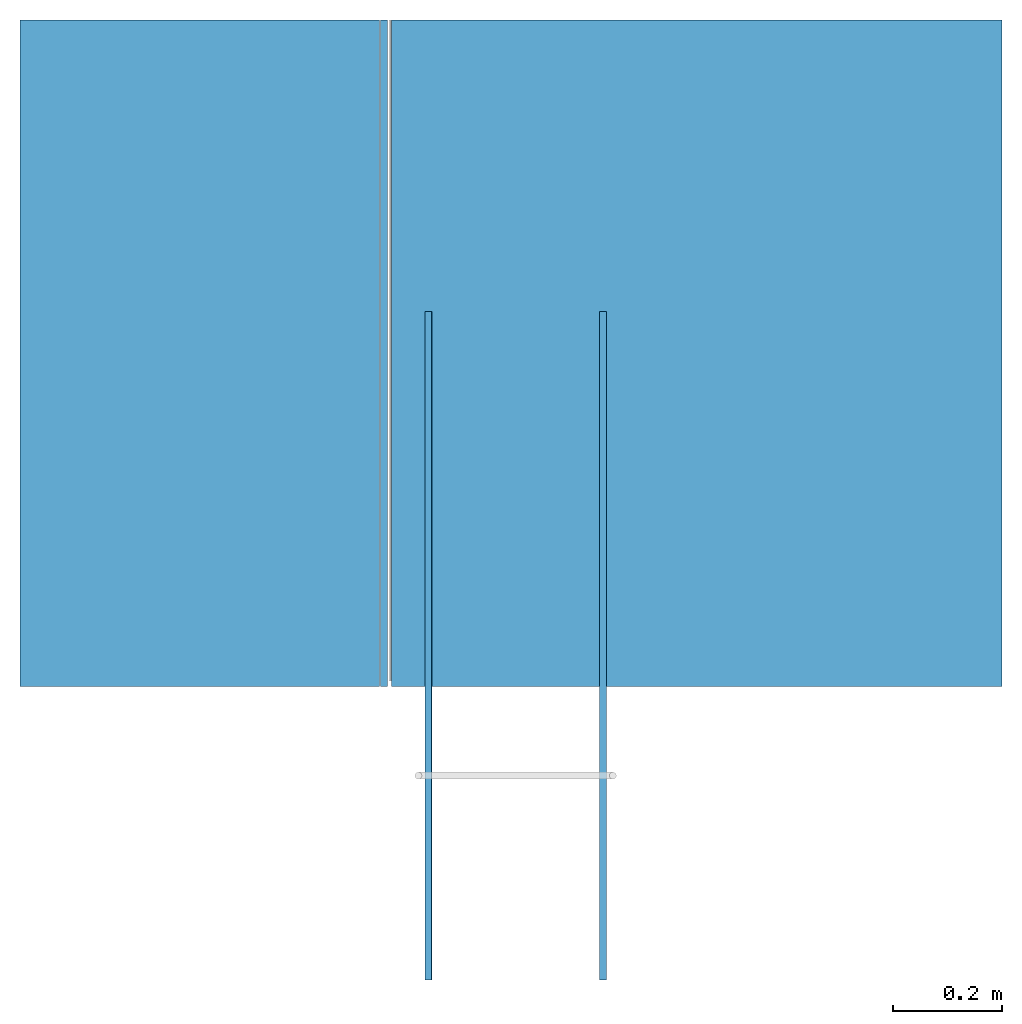
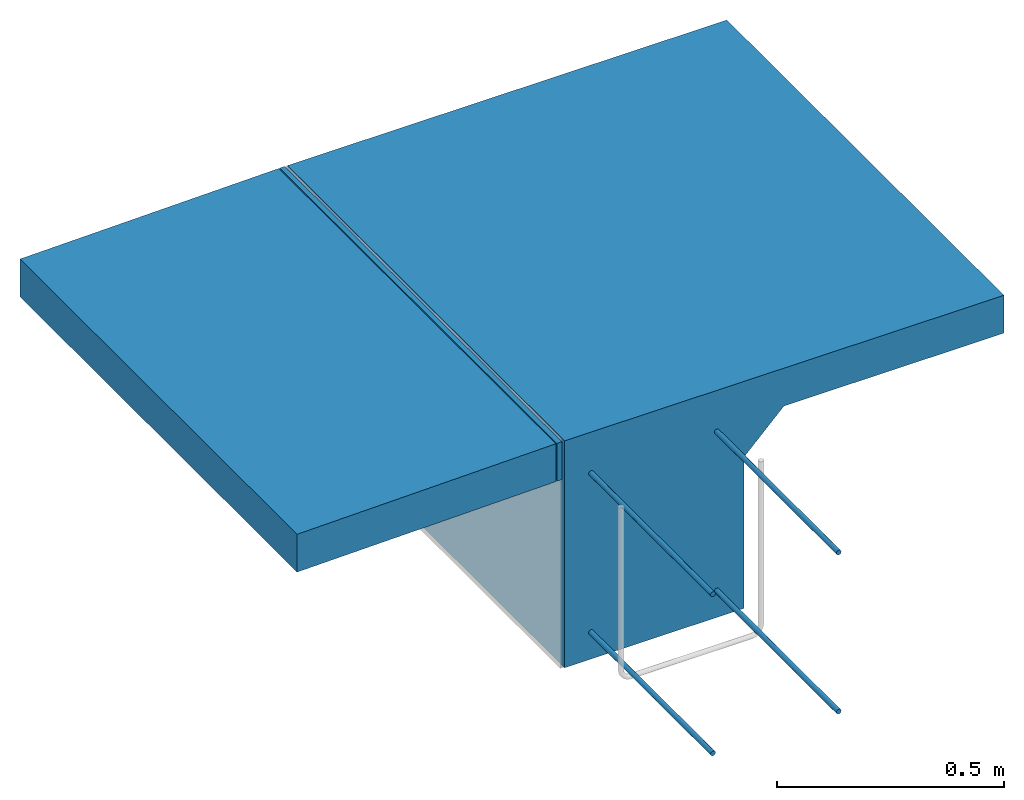
# One storey, part 1 of 2: 7 walls.
"""IFC4 building model written with IfcOpenShell, lengths in feet."""

from ifc_helpers import new_model, entity, si_unit, converted_unit, derived_unit, direction, frame, frame_2d, origin, place, context, subcontext, project, spatial, rectangle, extrude, material, type_object, element, save


model = new_model("IFC4")

# Units and contexts
model_context = context("Model", 3, precision=0.0001, world=origin(), true_north=direction((6.12303176911189e-17, 1.0)))
body_context = subcontext(model_context, "Body", "Model", "MODEL_VIEW")
ifc_project = project(units=[converted_unit("LENGTHUNIT", "FOOT", entity("IfcRatioMeasure", 0.3048), si_unit("LENGTHUNIT", "METRE"), dimensions=[1, 0, 0, 0, 0, 0, 0]), converted_unit("AREAUNIT", "SQUARE FOOT", entity("IfcRatioMeasure", 0.09290304), si_unit("AREAUNIT", "SQUARE_METRE"), dimensions=[2, 0, 0, 0, 0, 0, 0]), converted_unit("VOLUMEUNIT", "CUBIC FOOT", entity("IfcRatioMeasure", 0.028316846592), si_unit("VOLUMEUNIT", "CUBIC_METRE"), dimensions=[3, 0, 0, 0, 0, 0, 0]), converted_unit("PLANEANGLEUNIT", "DEGREE", entity("IfcRatioMeasure", 0.0174532925199433), si_unit("PLANEANGLEUNIT", "RADIAN"), dimensions=[0, 0, 0, 0, 0, 0, 0]), si_unit("MASSUNIT", "GRAM", prefix="KILO"), derived_unit("MASSDENSITYUNIT", [(si_unit("MASSUNIT", "GRAM", prefix="KILO"), 1), (si_unit("LENGTHUNIT", "METRE"), -3)]), derived_unit("MOMENTOFINERTIAUNIT", [(si_unit("LENGTHUNIT", "METRE"), 4)]), si_unit("TIMEUNIT", "SECOND"), si_unit("FREQUENCYUNIT", "HERTZ"), si_unit("THERMODYNAMICTEMPERATUREUNIT", "DEGREE_CELSIUS"), derived_unit("THERMALTRANSMITTANCEUNIT", [(si_unit("MASSUNIT", "GRAM", prefix="KILO"), 1), (si_unit("THERMODYNAMICTEMPERATUREUNIT", "KELVIN"), -1), (si_unit("TIMEUNIT", "SECOND"), -3)]), derived_unit("VOLUMETRICFLOWRATEUNIT", [(si_unit("LENGTHUNIT", "METRE"), 3), (si_unit("TIMEUNIT", "SECOND"), -1)]), si_unit("ELECTRICCURRENTUNIT", "AMPERE"), si_unit("ELECTRICVOLTAGEUNIT", "VOLT"), si_unit("POWERUNIT", "WATT"), si_unit("FORCEUNIT", "NEWTON"), si_unit("ILLUMINANCEUNIT", "LUX"), si_unit("LUMINOUSFLUXUNIT", "LUMEN"), si_unit("LUMINOUSINTENSITYUNIT", "CANDELA"), derived_unit("USERDEFINED", [(si_unit("MASSUNIT", "GRAM", prefix="KILO"), -1), (si_unit("LENGTHUNIT", "METRE"), -2), (si_unit("TIMEUNIT", "SECOND"), 3), (si_unit("LUMINOUSFLUXUNIT", "LUMEN"), 1)]), derived_unit("LINEARVELOCITYUNIT", [(si_unit("LENGTHUNIT", "METRE"), 1), (si_unit("TIMEUNIT", "SECOND"), -1)]), si_unit("PRESSUREUNIT", "PASCAL"), derived_unit("USERDEFINED", [(si_unit("LENGTHUNIT", "METRE"), -2), (si_unit("MASSUNIT", "GRAM", prefix="KILO"), 1), (si_unit("TIMEUNIT", "SECOND"), -2)]), derived_unit("LINEARFORCEUNIT", [(si_unit("MASSUNIT", "GRAM", prefix="KILO"), 1), (si_unit("LENGTHUNIT", "METRE"), 1), (si_unit("TIMEUNIT", "SECOND"), -2), (si_unit("LENGTHUNIT", "METRE"), -1)]), derived_unit("PLANARFORCEUNIT", [(si_unit("MASSUNIT", "GRAM", prefix="KILO"), 1), (si_unit("LENGTHUNIT", "METRE"), 1), (si_unit("TIMEUNIT", "SECOND"), -2), (si_unit("LENGTHUNIT", "METRE"), -2)])], contexts=[model_context])

# Site, building, storey
site_placement = place(None, origin())
site = spatial("IfcSite", under=ifc_project, at=site_placement, CompositionType="ELEMENT")
building_placement = place(site_placement, origin())
building = spatial("IfcBuilding", under=site, at=building_placement, CompositionType="ELEMENT")
storey_placement = place(building_placement, frame((0.0, 0.0, -8.0)))
storey = spatial("IfcBuildingStorey", under=building, at=storey_placement, CompositionType="ELEMENT", Elevation=-8.0)

# Walls
ifc_material_1 = material(Category="Materials")
wall_type_1 = type_object("IfcWallType", Name="Generic Models 680:Generic Models 1", PredefinedType="NOTDEFINED", material=ifc_material_1)
wall_1_placement = place(storey_placement, frame((1459.27121173765, 2.0, 6.0), z_axis=(0.0, 0.0, 1.0), x_axis=(0.0, 1.0, 0.0)))
cartesian_point_1 = entity("IfcCartesianPoint", [4.0, 0.0, 2.0])
vertex_point_1 = entity("IfcVertexPoint", cartesian_point_1)
cartesian_point_2 = entity("IfcCartesianPoint", [4.0, -3.66175012569693, 2.0])
vertex_point_2 = entity("IfcVertexPoint", cartesian_point_2)
ifc_direction_1 = entity("IfcDirection", [0.0, -1.0, 0.0])
edge_curve_1 = entity("IfcEdgeCurve", vertex_point_1, vertex_point_2, entity("IfcTrimmedCurve", entity("IfcLine", cartesian_point_1, entity("IfcVector", ifc_direction_1, 1.0)), [cartesian_point_1], [cartesian_point_2], True, "CARTESIAN"), True)
cartesian_point_3 = entity("IfcCartesianPoint", [4.0, -3.66175012569693, 1.66666666666667])
vertex_point_3 = entity("IfcVertexPoint", cartesian_point_3)
ifc_direction_2 = entity("IfcDirection", [0.0, 0.0, -1.0])
edge_curve_2 = entity("IfcEdgeCurve", vertex_point_2, vertex_point_3, entity("IfcTrimmedCurve", entity("IfcLine", cartesian_point_2, entity("IfcVector", ifc_direction_2, 1.0)), [cartesian_point_2], [cartesian_point_3], True, "CARTESIAN"), True)
cartesian_point_4 = entity("IfcCartesianPoint", [4.0, -1.82841679236344, 1.66666666666665])
vertex_point_4 = entity("IfcVertexPoint", cartesian_point_4)
ifc_direction_3 = entity("IfcDirection", [0.0, 1.0, 0.0])
edge_curve_3 = entity("IfcEdgeCurve", vertex_point_3, vertex_point_4, entity("IfcTrimmedCurve", entity("IfcLine", cartesian_point_3, entity("IfcVector", ifc_direction_3, 1.0)), [cartesian_point_3], [cartesian_point_4], True, "CARTESIAN"), True)
cartesian_point_5 = entity("IfcCartesianPoint", [4.0, -1.49508345903018, 1.33333333333333])
vertex_point_5 = entity("IfcVertexPoint", cartesian_point_5)
edge_curve_4 = entity("IfcEdgeCurve", vertex_point_4, vertex_point_5, entity("IfcTrimmedCurve", entity("IfcLine", cartesian_point_4, entity("IfcVector", entity("IfcDirection", [0.0, 0.707106781186483, -0.707106781186612]), 1.0)), [cartesian_point_4], [cartesian_point_5], True, "CARTESIAN"), True)
cartesian_point_6 = entity("IfcCartesianPoint", [4.0, -1.49508345903018, 0.0])
vertex_point_6 = entity("IfcVertexPoint", cartesian_point_6)
edge_curve_5 = entity("IfcEdgeCurve", vertex_point_5, vertex_point_6, entity("IfcTrimmedCurve", entity("IfcLine", cartesian_point_5, entity("IfcVector", ifc_direction_2, 1.0)), [cartesian_point_5], [cartesian_point_6], True, "CARTESIAN"), True)
cartesian_point_7 = entity("IfcCartesianPoint", [4.0, 0.0, 0.0])
vertex_point_7 = entity("IfcVertexPoint", cartesian_point_7)
edge_curve_6 = entity("IfcEdgeCurve", vertex_point_6, vertex_point_7, entity("IfcTrimmedCurve", entity("IfcLine", cartesian_point_6, entity("IfcVector", ifc_direction_3, 1.0)), [cartesian_point_6], [cartesian_point_7], True, "CARTESIAN"), True)
ifc_direction_4 = entity("IfcDirection", [0.0, 0.0, 1.0])
edge_curve_7 = entity("IfcEdgeCurve", vertex_point_7, vertex_point_1, entity("IfcTrimmedCurve", entity("IfcLine", cartesian_point_7, entity("IfcVector", ifc_direction_4, 1.0)), [cartesian_point_7], [cartesian_point_1], True, "CARTESIAN"), True)
ifc_direction_5 = entity("IfcDirection", [1.0, 0.0, 0.0])
cartesian_point_8 = entity("IfcCartesianPoint", [0.0, 0.0, 2.0])
vertex_point_8 = entity("IfcVertexPoint", cartesian_point_8)
cartesian_point_9 = entity("IfcCartesianPoint", [0.0, 0.0, 0.0])
vertex_point_9 = entity("IfcVertexPoint", cartesian_point_9)
edge_curve_8 = entity("IfcEdgeCurve", vertex_point_8, vertex_point_9, entity("IfcTrimmedCurve", entity("IfcLine", cartesian_point_8, entity("IfcVector", ifc_direction_2, 1.0)), [cartesian_point_8], [cartesian_point_9], True, "CARTESIAN"), True)
cartesian_point_10 = entity("IfcCartesianPoint", [0.0, -1.49508345903018, 0.0])
vertex_point_10 = entity("IfcVertexPoint", cartesian_point_10)
edge_curve_9 = entity("IfcEdgeCurve", vertex_point_9, vertex_point_10, entity("IfcTrimmedCurve", entity("IfcLine", cartesian_point_9, entity("IfcVector", ifc_direction_1, 1.0)), [cartesian_point_9], [cartesian_point_10], True, "CARTESIAN"), True)
cartesian_point_11 = entity("IfcCartesianPoint", [0.0, -1.49508345903018, 1.33333333333334])
vertex_point_11 = entity("IfcVertexPoint", cartesian_point_11)
edge_curve_10 = entity("IfcEdgeCurve", vertex_point_10, vertex_point_11, entity("IfcTrimmedCurve", entity("IfcLine", cartesian_point_10, entity("IfcVector", ifc_direction_4, 1.0)), [cartesian_point_10], [cartesian_point_11], True, "CARTESIAN"), True)
cartesian_point_12 = entity("IfcCartesianPoint", [0.0, -1.82841679236344, 1.66666666666665])
vertex_point_12 = entity("IfcVertexPoint", cartesian_point_12)
edge_curve_11 = entity("IfcEdgeCurve", vertex_point_11, vertex_point_12, entity("IfcTrimmedCurve", entity("IfcLine", cartesian_point_11, entity("IfcVector", entity("IfcDirection", [0.0, -0.707106781186483, 0.707106781186612]), 1.0)), [cartesian_point_11], [cartesian_point_12], True, "CARTESIAN"), True)
cartesian_point_13 = entity("IfcCartesianPoint", [0.0, -3.66175012569693, 1.66666666666667])
vertex_point_13 = entity("IfcVertexPoint", cartesian_point_13)
edge_curve_12 = entity("IfcEdgeCurve", vertex_point_12, vertex_point_13, entity("IfcTrimmedCurve", entity("IfcLine", cartesian_point_12, entity("IfcVector", ifc_direction_1, 1.0)), [cartesian_point_12], [cartesian_point_13], True, "CARTESIAN"), True)
cartesian_point_14 = entity("IfcCartesianPoint", [0.0, -3.66175012569693, 2.0])
vertex_point_14 = entity("IfcVertexPoint", cartesian_point_14)
edge_curve_13 = entity("IfcEdgeCurve", vertex_point_13, vertex_point_14, entity("IfcTrimmedCurve", entity("IfcLine", cartesian_point_13, entity("IfcVector", ifc_direction_4, 1.0)), [cartesian_point_13], [cartesian_point_14], True, "CARTESIAN"), True)
edge_curve_14 = entity("IfcEdgeCurve", vertex_point_14, vertex_point_8, entity("IfcTrimmedCurve", entity("IfcLine", cartesian_point_14, entity("IfcVector", ifc_direction_3, 1.0)), [cartesian_point_14], [cartesian_point_8], True, "CARTESIAN"), True)
ifc_direction_6 = entity("IfcDirection", [-1.0, 0.0, 0.0])
edge_curve_15 = entity("IfcEdgeCurve", vertex_point_14, vertex_point_2, entity("IfcTrimmedCurve", entity("IfcLine", cartesian_point_14, entity("IfcVector", ifc_direction_5, 1.0)), [cartesian_point_14], [cartesian_point_2], True, "CARTESIAN"), True)
edge_curve_16 = entity("IfcEdgeCurve", vertex_point_1, vertex_point_8, entity("IfcTrimmedCurve", entity("IfcLine", cartesian_point_8, entity("IfcVector", ifc_direction_6, 1.0)), [cartesian_point_1], [cartesian_point_8], True, "CARTESIAN"), True)
edge_curve_17 = entity("IfcEdgeCurve", vertex_point_13, vertex_point_3, entity("IfcTrimmedCurve", entity("IfcLine", cartesian_point_13, entity("IfcVector", ifc_direction_5, 1.0)), [cartesian_point_13], [cartesian_point_3], True, "CARTESIAN"), True)
edge_curve_18 = entity("IfcEdgeCurve", vertex_point_12, vertex_point_4, entity("IfcTrimmedCurve", entity("IfcLine", cartesian_point_12, entity("IfcVector", ifc_direction_5, 1.0)), [cartesian_point_12], [cartesian_point_4], True, "CARTESIAN"), True)
edge_curve_19 = entity("IfcEdgeCurve", vertex_point_7, vertex_point_9, entity("IfcTrimmedCurve", entity("IfcLine", cartesian_point_9, entity("IfcVector", ifc_direction_6, 1.0)), [cartesian_point_7], [cartesian_point_9], True, "CARTESIAN"), True)
edge_curve_20 = entity("IfcEdgeCurve", vertex_point_6, vertex_point_10, entity("IfcTrimmedCurve", entity("IfcLine", cartesian_point_10, entity("IfcVector", ifc_direction_6, 1.0)), [cartesian_point_6], [cartesian_point_10], True, "CARTESIAN"), True)
edge_curve_21 = entity("IfcEdgeCurve", vertex_point_5, vertex_point_11, entity("IfcTrimmedCurve", entity("IfcLine", cartesian_point_11, entity("IfcVector", ifc_direction_6, 1.0)), [cartesian_point_5], [cartesian_point_11], True, "CARTESIAN"), True)
element("IfcWall", 1, at=wall_1_placement, inside=storey, type_object=wall_type_1, material=ifc_material_1, Name="Generic Models 680:Generic Models 1", ObjectType="Generic Models 680:Generic Models 1", PredefinedType="NOTDEFINED", context=body_context, shape_type="AdvancedBrep", body=[
    entity("IfcAdvancedBrep", entity("IfcClosedShell", [entity("IfcAdvancedFace", [entity("IfcFaceOuterBound", entity("IfcEdgeLoop", [entity("IfcOrientedEdge", None, None, edge_curve_1, True), entity("IfcOrientedEdge", None, None, edge_curve_2, True), entity("IfcOrientedEdge", None, None, edge_curve_3, True), entity("IfcOrientedEdge", None, None, edge_curve_4, True), entity("IfcOrientedEdge", None, None, edge_curve_5, True), entity("IfcOrientedEdge", None, None, edge_curve_6, True), entity("IfcOrientedEdge", None, None, edge_curve_7, True)]), True)], entity("IfcPlane", entity("IfcAxis2Placement3D", entity("IfcCartesianPoint", [4.0, 0.0, 1.83333333333337]), ifc_direction_5, ifc_direction_4)), True), entity("IfcAdvancedFace", [entity("IfcFaceOuterBound", entity("IfcEdgeLoop", [entity("IfcOrientedEdge", None, None, edge_curve_8, True), entity("IfcOrientedEdge", None, None, edge_curve_9, True), entity("IfcOrientedEdge", None, None, edge_curve_10, True), entity("IfcOrientedEdge", None, None, edge_curve_11, True), entity("IfcOrientedEdge", None, None, edge_curve_12, True), entity("IfcOrientedEdge", None, None, edge_curve_13, True), entity("IfcOrientedEdge", None, None, edge_curve_14, True)]), True)], entity("IfcPlane", entity("IfcAxis2Placement3D", entity("IfcCartesianPoint", [0.0, 0.0, 1.83333333333337]), ifc_direction_6, ifc_direction_2)), True), entity("IfcAdvancedFace", [entity("IfcFaceOuterBound", entity("IfcEdgeLoop", [entity("IfcOrientedEdge", None, None, edge_curve_14, False), entity("IfcOrientedEdge", None, None, edge_curve_15, True), entity("IfcOrientedEdge", None, None, edge_curve_1, False), entity("IfcOrientedEdge", None, None, edge_curve_16, True)]), True)], entity("IfcPlane", entity("IfcAxis2Placement3D", cartesian_point_14, ifc_direction_4, ifc_direction_5)), True), entity("IfcAdvancedFace", [entity("IfcFaceOuterBound", entity("IfcEdgeLoop", [entity("IfcOrientedEdge", None, None, edge_curve_13, False), entity("IfcOrientedEdge", None, None, edge_curve_17, True), entity("IfcOrientedEdge", None, None, edge_curve_2, False), entity("IfcOrientedEdge", None, None, edge_curve_15, False)]), True)], entity("IfcPlane", entity("IfcAxis2Placement3D", cartesian_point_13, ifc_direction_1, ifc_direction_5)), True), entity("IfcAdvancedFace", [entity("IfcFaceOuterBound", entity("IfcEdgeLoop", [entity("IfcOrientedEdge", None, None, edge_curve_12, False), entity("IfcOrientedEdge", None, None, edge_curve_18, True), entity("IfcOrientedEdge", None, None, edge_curve_3, False), entity("IfcOrientedEdge", None, None, edge_curve_17, False)]), True)], entity("IfcPlane", entity("IfcAxis2Placement3D", cartesian_point_12, ifc_direction_2, ifc_direction_5)), True), entity("IfcAdvancedFace", [entity("IfcFaceOuterBound", entity("IfcEdgeLoop", [entity("IfcOrientedEdge", None, None, edge_curve_8, False), entity("IfcOrientedEdge", None, None, edge_curve_16, False), entity("IfcOrientedEdge", None, None, edge_curve_7, False), entity("IfcOrientedEdge", None, None, edge_curve_19, True)]), True)], entity("IfcPlane", entity("IfcAxis2Placement3D", cartesian_point_8, ifc_direction_3, ifc_direction_5)), True), entity("IfcAdvancedFace", [entity("IfcFaceOuterBound", entity("IfcEdgeLoop", [entity("IfcOrientedEdge", None, None, edge_curve_9, False), entity("IfcOrientedEdge", None, None, edge_curve_19, False), entity("IfcOrientedEdge", None, None, edge_curve_6, False), entity("IfcOrientedEdge", None, None, edge_curve_20, True)]), True)], entity("IfcPlane", entity("IfcAxis2Placement3D", cartesian_point_9, ifc_direction_2, ifc_direction_5)), True), entity("IfcAdvancedFace", [entity("IfcFaceOuterBound", entity("IfcEdgeLoop", [entity("IfcOrientedEdge", None, None, edge_curve_10, False), entity("IfcOrientedEdge", None, None, edge_curve_20, False), entity("IfcOrientedEdge", None, None, edge_curve_5, False), entity("IfcOrientedEdge", None, None, edge_curve_21, True)]), True)], entity("IfcPlane", entity("IfcAxis2Placement3D", cartesian_point_10, ifc_direction_1, ifc_direction_5)), True), entity("IfcAdvancedFace", [entity("IfcFaceOuterBound", entity("IfcEdgeLoop", [entity("IfcOrientedEdge", None, None, edge_curve_11, False), entity("IfcOrientedEdge", None, None, edge_curve_21, False), entity("IfcOrientedEdge", None, None, edge_curve_4, False), entity("IfcOrientedEdge", None, None, edge_curve_18, False)]), True)], entity("IfcPlane", entity("IfcAxis2Placement3D", cartesian_point_11, entity("IfcDirection", [0.0, -0.707106781186607, -0.707106781186488]), ifc_direction_5)), True)])),
])
ifc_material_2 = material(Category="Materials")
wall_type_2 = type_object("IfcWallType", Name="Generic Models 668:Generic Models 1", PredefinedType="NOTDEFINED", material=ifc_material_2)
wall_2_placement = place(storey_placement, frame((1457.04264332935, 2.0, 7.62336420814936), z_axis=(0.0, 0.0, 1.0), x_axis=(0.0, 1.0, 0.0)))
element("IfcWall", 2, at=wall_2_placement, inside=storey, type_object=wall_type_2, material=ifc_material_2, Name="Generic Models 668:Generic Models 1", ObjectType="Generic Models 668:Generic Models 1", PredefinedType="NOTDEFINED", context=body_context, shape_type="SweptSolid", body=[
    extrude(rectangle(XDim=2.15667589667491, YDim=4.0, at=frame_2d((5.55111512312578e-16, 0.0), x_axis=(0.0, 1.0))), frame((2.0, -1.07812542152192, 0.021408089424752), z_axis=(0.0, 0.0198528573141237, 0.999802912606512), x_axis=(1.0, 0.0, 0.0)), (0.0, -0.0198528573141237, 0.999802912606512), 0.333333333333333),
])
ifc_material_3 = material(Category="Materials")
wall_type_3 = type_object("IfcWallType", Name="Generic Models 691:Generic Models 1", PredefinedType="NOTDEFINED", material=ifc_material_3)
wall_3_placement = place(storey_placement, frame((1459.20689886983, 2.0, 7.6666666666576), z_axis=(0.0, 0.0, 1.0), x_axis=(0.0, 1.0, 0.0)))
element("IfcWall", 3, at=wall_3_placement, inside=storey, type_object=wall_type_3, material=ifc_material_3, Name="Generic Models 691:Generic Models 1", ObjectType="Generic Models 691:Generic Models 1", PredefinedType="NOTDEFINED", context=body_context, shape_type="SweptSolid", body=[
    extrude(rectangle(XDim=4.0, YDim=0.0416666666665151, at=frame_2d((-2.22044604925031e-16, 0.0), x_axis=(1.0, 0.0))), frame((2.0, -0.0208333333332575, 0.0)), (0.0, 0.0, 1.0), 0.333333333333333),
])
ifc_material_4 = material(Category="Materials")
wall_type_4 = type_object("IfcWallType", Name="Generic Models 694:Generic Models 1", PredefinedType="NOTDEFINED", material=ifc_material_4)
wall_4_placement = place(storey_placement, frame((1459.47148033135, 0.240276800300764, 7.61761915782175), z_axis=(0.0, 0.0, 1.0), x_axis=(0.0, 1.0, 0.0)))
cartesian_point_15 = entity("IfcCartesianPoint", [4.009723199695, -0.0416666666665151, 0.0208333333333343])
vertex_point_15 = entity("IfcVertexPoint", cartesian_point_15)
cartesian_point_16 = entity("IfcCartesianPoint", [4.009723199695, 0.0, 0.0208333333333344])
vertex_point_16 = entity("IfcVertexPoint", cartesian_point_16)
cartesian_point_17 = entity("IfcCartesianPoint", [4.009723199695, -0.0208333333332575, 0.0208333333333344])
ifc_direction_7 = entity("IfcDirection", [1.0, 0.0, 0.0])
ifc_direction_8 = entity("IfcDirection", [0.0, 1.0, 0.0])
edge_curve_22 = entity("IfcEdgeCurve", vertex_point_15, vertex_point_16, entity("IfcTrimmedCurve", entity("IfcCircle", entity("IfcAxis2Placement3D", cartesian_point_17, ifc_direction_7, ifc_direction_8), 0.0208333333333333), [cartesian_point_15], [cartesian_point_16], True, "CARTESIAN"), True)
edge_curve_23 = entity("IfcEdgeCurve", vertex_point_16, vertex_point_15, entity("IfcTrimmedCurve", entity("IfcCircle", entity("IfcAxis2Placement3D", cartesian_point_17, ifc_direction_7, ifc_direction_8), 0.0208333333333333), [cartesian_point_16], [cartesian_point_15], True, "CARTESIAN"), True)
cartesian_point_18 = entity("IfcCartesianPoint", [0.0, -0.0416666666665151, 0.0208333333333334])
vertex_point_17 = entity("IfcVertexPoint", cartesian_point_18)
cartesian_point_19 = entity("IfcCartesianPoint", [0.0, 0.0, 0.0208333333333335])
vertex_point_18 = entity("IfcVertexPoint", cartesian_point_19)
cartesian_point_20 = entity("IfcCartesianPoint", [0.0, -0.0208333333332575, 0.0208333333333335])
ifc_direction_9 = entity("IfcDirection", [-1.0, 0.0, 0.0])
edge_curve_24 = entity("IfcEdgeCurve", vertex_point_17, vertex_point_18, entity("IfcTrimmedCurve", entity("IfcCircle", entity("IfcAxis2Placement3D", cartesian_point_20, ifc_direction_9, ifc_direction_8), 0.0208333333333333), [cartesian_point_18], [cartesian_point_19], True, "CARTESIAN"), True)
edge_curve_25 = entity("IfcEdgeCurve", vertex_point_18, vertex_point_17, entity("IfcTrimmedCurve", entity("IfcCircle", entity("IfcAxis2Placement3D", cartesian_point_20, ifc_direction_9, ifc_direction_8), 0.0208333333333333), [cartesian_point_19], [cartesian_point_18], True, "CARTESIAN"), True)
edge_curve_26 = entity("IfcEdgeCurve", vertex_point_18, vertex_point_16, entity("IfcTrimmedCurve", entity("IfcLine", cartesian_point_19, entity("IfcVector", ifc_direction_7, 1.0)), [cartesian_point_19], [cartesian_point_16], True, "CARTESIAN"), True)
edge_curve_27 = entity("IfcEdgeCurve", vertex_point_15, vertex_point_17, entity("IfcTrimmedCurve", entity("IfcLine", cartesian_point_18, entity("IfcVector", ifc_direction_9, 1.0)), [cartesian_point_15], [cartesian_point_18], True, "CARTESIAN"), True)
element("IfcWall", 4, at=wall_4_placement, inside=storey, type_object=wall_type_4, material=ifc_material_4, Name="Generic Models 694:Generic Models 1", ObjectType="Generic Models 694:Generic Models 1", PredefinedType="NOTDEFINED", context=body_context, shape_type="AdvancedBrep", body=[
    entity("IfcAdvancedBrep", entity("IfcClosedShell", [entity("IfcAdvancedFace", [entity("IfcFaceOuterBound", entity("IfcEdgeLoop", [entity("IfcOrientedEdge", None, None, edge_curve_22, True), entity("IfcOrientedEdge", None, None, edge_curve_23, True)]), True)], entity("IfcPlane", entity("IfcAxis2Placement3D", cartesian_point_16, ifc_direction_7, entity("IfcDirection", [0.0, 0.0, 1.0]))), True), entity("IfcAdvancedFace", [entity("IfcFaceOuterBound", entity("IfcEdgeLoop", [entity("IfcOrientedEdge", None, None, edge_curve_24, True), entity("IfcOrientedEdge", None, None, edge_curve_25, True)]), True)], entity("IfcPlane", entity("IfcAxis2Placement3D", cartesian_point_19, ifc_direction_9, entity("IfcDirection", [0.0, 0.0, -1.0]))), True), entity("IfcAdvancedFace", [entity("IfcFaceOuterBound", entity("IfcEdgeLoop", [entity("IfcOrientedEdge", None, None, edge_curve_25, False), entity("IfcOrientedEdge", None, None, edge_curve_26, True), entity("IfcOrientedEdge", None, None, edge_curve_22, False), entity("IfcOrientedEdge", None, None, edge_curve_27, True)]), True)], entity("IfcCylindricalSurface", entity("IfcAxis2Placement3D", cartesian_point_17, ifc_direction_9, ifc_direction_8), 0.0208333333333333), True), entity("IfcAdvancedFace", [entity("IfcFaceOuterBound", entity("IfcEdgeLoop", [entity("IfcOrientedEdge", None, None, edge_curve_24, False), entity("IfcOrientedEdge", None, None, edge_curve_27, False), entity("IfcOrientedEdge", None, None, edge_curve_23, False), entity("IfcOrientedEdge", None, None, edge_curve_26, False)]), True)], entity("IfcCylindricalSurface", entity("IfcAxis2Placement3D", cartesian_point_17, ifc_direction_9, ifc_direction_8), 0.0208333333333333), True)])),
])
wall_type_5 = type_object("IfcWallType", Name="Generic Models 695:Generic Models 1", PredefinedType="NOTDEFINED", material=ifc_material_4)
wall_5_placement = place(storey_placement, frame((1460.51944339535, 0.240276800300764, 7.61761915782175), z_axis=(0.0, 0.0, 1.0), x_axis=(0.0, 1.0, 0.0)))
cartesian_point_21 = entity("IfcCartesianPoint", [4.009723199695, 0.0, 0.0208333333333344])
vertex_point_19 = entity("IfcVertexPoint", cartesian_point_21)
cartesian_point_22 = entity("IfcCartesianPoint", [4.009723199695, -0.0416666666665151, 0.0208333333333344])
vertex_point_20 = entity("IfcVertexPoint", cartesian_point_22)
cartesian_point_23 = entity("IfcCartesianPoint", [4.009723199695, -0.0208333333332575, 0.0208333333333344])
ifc_direction_10 = entity("IfcDirection", [1.0, 0.0, 0.0])
ifc_direction_11 = entity("IfcDirection", [0.0, -1.0, 0.0])
edge_curve_28 = entity("IfcEdgeCurve", vertex_point_19, vertex_point_20, entity("IfcTrimmedCurve", entity("IfcCircle", entity("IfcAxis2Placement3D", cartesian_point_23, ifc_direction_10, ifc_direction_11), 0.0208333333333333), [cartesian_point_21], [cartesian_point_22], True, "CARTESIAN"), True)
edge_curve_29 = entity("IfcEdgeCurve", vertex_point_20, vertex_point_19, entity("IfcTrimmedCurve", entity("IfcCircle", entity("IfcAxis2Placement3D", cartesian_point_23, ifc_direction_10, ifc_direction_11), 0.0208333333333333), [cartesian_point_22], [cartesian_point_21], True, "CARTESIAN"), True)
cartesian_point_24 = entity("IfcCartesianPoint", [0.0, 0.0, 0.0208333333333335])
vertex_point_21 = entity("IfcVertexPoint", cartesian_point_24)
cartesian_point_25 = entity("IfcCartesianPoint", [0.0, -0.0416666666665151, 0.0208333333333333])
vertex_point_22 = entity("IfcVertexPoint", cartesian_point_25)
cartesian_point_26 = entity("IfcCartesianPoint", [0.0, -0.0208333333332575, 0.0208333333333335])
ifc_direction_12 = entity("IfcDirection", [-1.0, 0.0, 0.0])
edge_curve_30 = entity("IfcEdgeCurve", vertex_point_21, vertex_point_22, entity("IfcTrimmedCurve", entity("IfcCircle", entity("IfcAxis2Placement3D", cartesian_point_26, ifc_direction_12, ifc_direction_11), 0.0208333333333333), [cartesian_point_24], [cartesian_point_25], True, "CARTESIAN"), True)
edge_curve_31 = entity("IfcEdgeCurve", vertex_point_22, vertex_point_21, entity("IfcTrimmedCurve", entity("IfcCircle", entity("IfcAxis2Placement3D", cartesian_point_26, ifc_direction_12, ifc_direction_11), 0.0208333333333333), [cartesian_point_25], [cartesian_point_24], True, "CARTESIAN"), True)
edge_curve_32 = entity("IfcEdgeCurve", vertex_point_21, vertex_point_19, entity("IfcTrimmedCurve", entity("IfcLine", cartesian_point_24, entity("IfcVector", ifc_direction_10, 1.0)), [cartesian_point_24], [cartesian_point_21], True, "CARTESIAN"), True)
edge_curve_33 = entity("IfcEdgeCurve", vertex_point_20, vertex_point_22, entity("IfcTrimmedCurve", entity("IfcLine", cartesian_point_25, entity("IfcVector", ifc_direction_12, 1.0)), [cartesian_point_22], [cartesian_point_25], True, "CARTESIAN"), True)
element("IfcWall", 5, at=wall_5_placement, inside=storey, type_object=wall_type_5, material=ifc_material_4, Name="Generic Models 695:Generic Models 1", ObjectType="Generic Models 695:Generic Models 1", PredefinedType="NOTDEFINED", context=body_context, shape_type="AdvancedBrep", body=[
    entity("IfcAdvancedBrep", entity("IfcClosedShell", [entity("IfcAdvancedFace", [entity("IfcFaceOuterBound", entity("IfcEdgeLoop", [entity("IfcOrientedEdge", None, None, edge_curve_28, True), entity("IfcOrientedEdge", None, None, edge_curve_29, True)]), True)], entity("IfcPlane", entity("IfcAxis2Placement3D", cartesian_point_22, ifc_direction_10, entity("IfcDirection", [0.0, 0.0, -1.0]))), True), entity("IfcAdvancedFace", [entity("IfcFaceOuterBound", entity("IfcEdgeLoop", [entity("IfcOrientedEdge", None, None, edge_curve_30, True), entity("IfcOrientedEdge", None, None, edge_curve_31, True)]), True)], entity("IfcPlane", entity("IfcAxis2Placement3D", cartesian_point_25, ifc_direction_12, entity("IfcDirection", [0.0, 0.0, 1.0]))), True), entity("IfcAdvancedFace", [entity("IfcFaceOuterBound", entity("IfcEdgeLoop", [entity("IfcOrientedEdge", None, None, edge_curve_30, False), entity("IfcOrientedEdge", None, None, edge_curve_32, True), entity("IfcOrientedEdge", None, None, edge_curve_29, False), entity("IfcOrientedEdge", None, None, edge_curve_33, True)]), True)], entity("IfcCylindricalSurface", entity("IfcAxis2Placement3D", cartesian_point_23, ifc_direction_12, ifc_direction_11), 0.0208333333333333), True), entity("IfcAdvancedFace", [entity("IfcFaceOuterBound", entity("IfcEdgeLoop", [entity("IfcOrientedEdge", None, None, edge_curve_31, False), entity("IfcOrientedEdge", None, None, edge_curve_33, False), entity("IfcOrientedEdge", None, None, edge_curve_28, False), entity("IfcOrientedEdge", None, None, edge_curve_32, False)]), True)], entity("IfcCylindricalSurface", entity("IfcAxis2Placement3D", cartesian_point_23, ifc_direction_12, ifc_direction_11), 0.0208333333333333), True)])),
])
wall_type_6 = type_object("IfcWallType", Name="Generic Models 696:Generic Models 1", PredefinedType="NOTDEFINED", material=ifc_material_4)
wall_6_placement = place(storey_placement, frame((1459.47148033135, 0.240276800300764, 6.21571417549347), z_axis=(0.0, 0.0, 1.0), x_axis=(0.0, 1.0, 0.0)))
cartesian_point_27 = entity("IfcCartesianPoint", [4.009723199695, -0.0416666666665151, 0.020833333333333])
vertex_point_23 = entity("IfcVertexPoint", cartesian_point_27)
cartesian_point_28 = entity("IfcCartesianPoint", [4.009723199695, 0.0, 0.020833333333333])
vertex_point_24 = entity("IfcVertexPoint", cartesian_point_28)
cartesian_point_29 = entity("IfcCartesianPoint", [4.009723199695, -0.0208333333332575, 0.020833333333333])
ifc_direction_13 = entity("IfcDirection", [1.0, 0.0, 0.0])
ifc_direction_14 = entity("IfcDirection", [0.0, 1.0, 0.0])
edge_curve_34 = entity("IfcEdgeCurve", vertex_point_23, vertex_point_24, entity("IfcTrimmedCurve", entity("IfcCircle", entity("IfcAxis2Placement3D", cartesian_point_29, ifc_direction_13, ifc_direction_14), 0.0208333333333333), [cartesian_point_27], [cartesian_point_28], True, "CARTESIAN"), True)
edge_curve_35 = entity("IfcEdgeCurve", vertex_point_24, vertex_point_23, entity("IfcTrimmedCurve", entity("IfcCircle", entity("IfcAxis2Placement3D", cartesian_point_29, ifc_direction_13, ifc_direction_14), 0.0208333333333333), [cartesian_point_28], [cartesian_point_27], True, "CARTESIAN"), True)
cartesian_point_30 = entity("IfcCartesianPoint", [0.0, -0.0416666666665151, 0.0208333333333339])
vertex_point_25 = entity("IfcVertexPoint", cartesian_point_30)
cartesian_point_31 = entity("IfcCartesianPoint", [0.0, 0.0, 0.0208333333333339])
vertex_point_26 = entity("IfcVertexPoint", cartesian_point_31)
cartesian_point_32 = entity("IfcCartesianPoint", [0.0, -0.0208333333332575, 0.0208333333333339])
ifc_direction_15 = entity("IfcDirection", [-1.0, 0.0, 0.0])
edge_curve_36 = entity("IfcEdgeCurve", vertex_point_25, vertex_point_26, entity("IfcTrimmedCurve", entity("IfcCircle", entity("IfcAxis2Placement3D", cartesian_point_32, ifc_direction_15, ifc_direction_14), 0.0208333333333333), [cartesian_point_30], [cartesian_point_31], True, "CARTESIAN"), True)
edge_curve_37 = entity("IfcEdgeCurve", vertex_point_26, vertex_point_25, entity("IfcTrimmedCurve", entity("IfcCircle", entity("IfcAxis2Placement3D", cartesian_point_32, ifc_direction_15, ifc_direction_14), 0.0208333333333333), [cartesian_point_31], [cartesian_point_30], True, "CARTESIAN"), True)
edge_curve_38 = entity("IfcEdgeCurve", vertex_point_25, vertex_point_23, entity("IfcTrimmedCurve", entity("IfcLine", cartesian_point_30, entity("IfcVector", ifc_direction_13, 1.0)), [cartesian_point_30], [cartesian_point_27], True, "CARTESIAN"), True)
edge_curve_39 = entity("IfcEdgeCurve", vertex_point_24, vertex_point_26, entity("IfcTrimmedCurve", entity("IfcLine", cartesian_point_31, entity("IfcVector", ifc_direction_15, 1.0)), [cartesian_point_28], [cartesian_point_31], True, "CARTESIAN"), True)
element("IfcWall", 6, at=wall_6_placement, inside=storey, type_object=wall_type_6, material=ifc_material_4, Name="Generic Models 696:Generic Models 1", ObjectType="Generic Models 696:Generic Models 1", PredefinedType="NOTDEFINED", context=body_context, shape_type="AdvancedBrep", body=[
    entity("IfcAdvancedBrep", entity("IfcClosedShell", [entity("IfcAdvancedFace", [entity("IfcFaceOuterBound", entity("IfcEdgeLoop", [entity("IfcOrientedEdge", None, None, edge_curve_34, True), entity("IfcOrientedEdge", None, None, edge_curve_35, True)]), True)], entity("IfcPlane", entity("IfcAxis2Placement3D", cartesian_point_28, ifc_direction_13, entity("IfcDirection", [0.0, 0.0, 1.0]))), True), entity("IfcAdvancedFace", [entity("IfcFaceOuterBound", entity("IfcEdgeLoop", [entity("IfcOrientedEdge", None, None, edge_curve_36, True), entity("IfcOrientedEdge", None, None, edge_curve_37, True)]), True)], entity("IfcPlane", entity("IfcAxis2Placement3D", cartesian_point_31, ifc_direction_15, entity("IfcDirection", [0.0, 0.0, -1.0]))), True), entity("IfcAdvancedFace", [entity("IfcFaceOuterBound", entity("IfcEdgeLoop", [entity("IfcOrientedEdge", None, None, edge_curve_36, False), entity("IfcOrientedEdge", None, None, edge_curve_38, True), entity("IfcOrientedEdge", None, None, edge_curve_35, False), entity("IfcOrientedEdge", None, None, edge_curve_39, True)]), True)], entity("IfcCylindricalSurface", entity("IfcAxis2Placement3D", cartesian_point_29, ifc_direction_15, ifc_direction_14), 0.0208333333333333), True), entity("IfcAdvancedFace", [entity("IfcFaceOuterBound", entity("IfcEdgeLoop", [entity("IfcOrientedEdge", None, None, edge_curve_37, False), entity("IfcOrientedEdge", None, None, edge_curve_39, False), entity("IfcOrientedEdge", None, None, edge_curve_34, False), entity("IfcOrientedEdge", None, None, edge_curve_38, False)]), True)], entity("IfcCylindricalSurface", entity("IfcAxis2Placement3D", cartesian_point_29, ifc_direction_15, ifc_direction_14), 0.0208333333333333), True)])),
])
wall_type_7 = type_object("IfcWallType", Name="Generic Models 697:Generic Models 1", PredefinedType="NOTDEFINED", material=ifc_material_4)
wall_7_placement = place(storey_placement, frame((1460.51944339535, 0.240276800300764, 6.21571417549347), z_axis=(0.0, 0.0, 1.0), x_axis=(0.0, 1.0, 0.0)))
cartesian_point_33 = entity("IfcCartesianPoint", [4.009723199695, 0.0, 0.020833333333333])
vertex_point_27 = entity("IfcVertexPoint", cartesian_point_33)
cartesian_point_34 = entity("IfcCartesianPoint", [4.009723199695, -0.0416666666665151, 0.020833333333333])
vertex_point_28 = entity("IfcVertexPoint", cartesian_point_34)
cartesian_point_35 = entity("IfcCartesianPoint", [4.009723199695, -0.0208333333332575, 0.020833333333333])
ifc_direction_16 = entity("IfcDirection", [1.0, 0.0, 0.0])
ifc_direction_17 = entity("IfcDirection", [0.0, -1.0, 0.0])
edge_curve_40 = entity("IfcEdgeCurve", vertex_point_27, vertex_point_28, entity("IfcTrimmedCurve", entity("IfcCircle", entity("IfcAxis2Placement3D", cartesian_point_35, ifc_direction_16, ifc_direction_17), 0.0208333333333333), [cartesian_point_33], [cartesian_point_34], True, "CARTESIAN"), True)
edge_curve_41 = entity("IfcEdgeCurve", vertex_point_28, vertex_point_27, entity("IfcTrimmedCurve", entity("IfcCircle", entity("IfcAxis2Placement3D", cartesian_point_35, ifc_direction_16, ifc_direction_17), 0.0208333333333333), [cartesian_point_34], [cartesian_point_33], True, "CARTESIAN"), True)
cartesian_point_36 = entity("IfcCartesianPoint", [0.0, 0.0, 0.0208333333333339])
vertex_point_29 = entity("IfcVertexPoint", cartesian_point_36)
cartesian_point_37 = entity("IfcCartesianPoint", [0.0, -0.0416666666665151, 0.0208333333333337])
vertex_point_30 = entity("IfcVertexPoint", cartesian_point_37)
cartesian_point_38 = entity("IfcCartesianPoint", [0.0, -0.0208333333332575, 0.0208333333333339])
ifc_direction_18 = entity("IfcDirection", [-1.0, 0.0, 0.0])
edge_curve_42 = entity("IfcEdgeCurve", vertex_point_29, vertex_point_30, entity("IfcTrimmedCurve", entity("IfcCircle", entity("IfcAxis2Placement3D", cartesian_point_38, ifc_direction_18, ifc_direction_17), 0.0208333333333333), [cartesian_point_36], [cartesian_point_37], True, "CARTESIAN"), True)
edge_curve_43 = entity("IfcEdgeCurve", vertex_point_30, vertex_point_29, entity("IfcTrimmedCurve", entity("IfcCircle", entity("IfcAxis2Placement3D", cartesian_point_38, ifc_direction_18, ifc_direction_17), 0.0208333333333333), [cartesian_point_37], [cartesian_point_36], True, "CARTESIAN"), True)
edge_curve_44 = entity("IfcEdgeCurve", vertex_point_30, vertex_point_28, entity("IfcTrimmedCurve", entity("IfcLine", cartesian_point_37, entity("IfcVector", ifc_direction_16, 1.0)), [cartesian_point_37], [cartesian_point_34], True, "CARTESIAN"), True)
edge_curve_45 = entity("IfcEdgeCurve", vertex_point_27, vertex_point_29, entity("IfcTrimmedCurve", entity("IfcLine", cartesian_point_36, entity("IfcVector", ifc_direction_18, 1.0)), [cartesian_point_33], [cartesian_point_36], True, "CARTESIAN"), True)
element("IfcWall", 7, at=wall_7_placement, inside=storey, type_object=wall_type_7, material=ifc_material_4, Name="Generic Models 697:Generic Models 1", ObjectType="Generic Models 697:Generic Models 1", PredefinedType="NOTDEFINED", context=body_context, shape_type="AdvancedBrep", body=[
    entity("IfcAdvancedBrep", entity("IfcClosedShell", [entity("IfcAdvancedFace", [entity("IfcFaceOuterBound", entity("IfcEdgeLoop", [entity("IfcOrientedEdge", None, None, edge_curve_40, True), entity("IfcOrientedEdge", None, None, edge_curve_41, True)]), True)], entity("IfcPlane", entity("IfcAxis2Placement3D", cartesian_point_34, ifc_direction_16, entity("IfcDirection", [0.0, 0.0, -1.0]))), True), entity("IfcAdvancedFace", [entity("IfcFaceOuterBound", entity("IfcEdgeLoop", [entity("IfcOrientedEdge", None, None, edge_curve_42, True), entity("IfcOrientedEdge", None, None, edge_curve_43, True)]), True)], entity("IfcPlane", entity("IfcAxis2Placement3D", cartesian_point_37, ifc_direction_18, entity("IfcDirection", [0.0, 0.0, 1.0]))), True), entity("IfcAdvancedFace", [entity("IfcFaceOuterBound", entity("IfcEdgeLoop", [entity("IfcOrientedEdge", None, None, edge_curve_43, False), entity("IfcOrientedEdge", None, None, edge_curve_44, True), entity("IfcOrientedEdge", None, None, edge_curve_40, False), entity("IfcOrientedEdge", None, None, edge_curve_45, True)]), True)], entity("IfcCylindricalSurface", entity("IfcAxis2Placement3D", cartesian_point_35, ifc_direction_18, ifc_direction_17), 0.0208333333333333), True), entity("IfcAdvancedFace", [entity("IfcFaceOuterBound", entity("IfcEdgeLoop", [entity("IfcOrientedEdge", None, None, edge_curve_42, False), entity("IfcOrientedEdge", None, None, edge_curve_45, False), entity("IfcOrientedEdge", None, None, edge_curve_41, False), entity("IfcOrientedEdge", None, None, edge_curve_44, False)]), True)], entity("IfcCylindricalSurface", entity("IfcAxis2Placement3D", cartesian_point_35, ifc_direction_18, ifc_direction_17), 0.0208333333333333), True)])),
])

save(model, "model.ifc")
